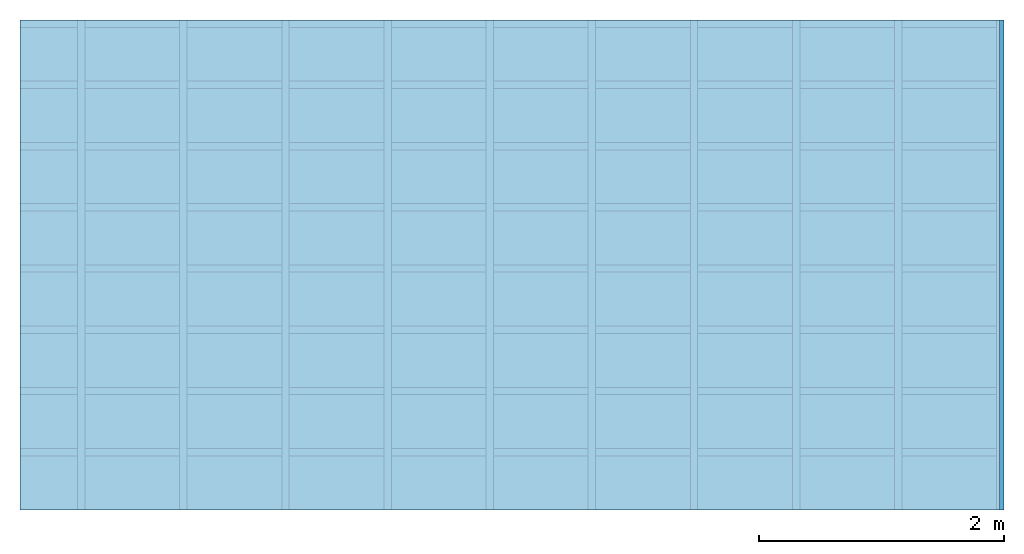
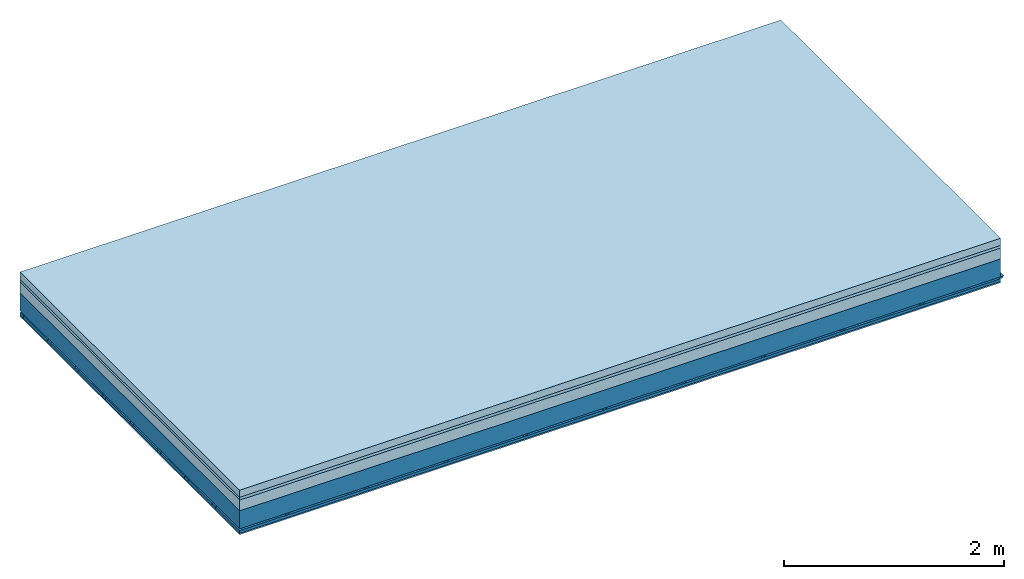
# One storey: 4 members, 4 plates, 1 element without a shape of its own.
"""IFC4 building model written with IfcOpenShell, lengths in metres."""

from ifc_helpers import new_model, si_unit, derived_unit, direction, frame, frame_2d, origin, origin_with_axes, place, context, project, spatial, polyline, rectangle, outline, extrude, material, layer, layer_set, type_object, element, aggregate, save


model = new_model("IFC4")

# Units and contexts
plan_context = context("Plan", 3, precision=1e-05, world=origin(), true_north=direction((0.0, 1.0)))
model_context = context("Model", 3, precision=1e-05, world=origin(), true_north=direction((0.0, 1.0)))
ifc_project = project(units=[si_unit("LENGTHUNIT", "METRE"), derived_unit("SOUNDPRESSUREUNIT", [(si_unit("PRESSUREUNIT", "PASCAL", prefix="MICRO"), 0)]), si_unit("ENERGYUNIT", "JOULE", prefix="MEGA"), si_unit("MASSUNIT", "GRAM", prefix="KILO"), derived_unit("THERMALTRANSMITTANCEUNIT", [(si_unit("POWERUNIT", "WATT"), 1), (si_unit("AREAUNIT", "SQUARE_METRE"), -1), (si_unit("THERMODYNAMICTEMPERATUREUNIT", "KELVIN"), -1)]), derived_unit("AREADENSITYUNIT", [(si_unit("MASSUNIT", "GRAM", prefix="KILO"), 1), (si_unit("AREAUNIT", "SQUARE_METRE"), -1)]), derived_unit("USERDEFINED", [(si_unit("ENERGYUNIT", "JOULE", prefix="MEGA"), 1), (si_unit("AREAUNIT", "SQUARE_METRE"), -1)])], contexts=[plan_context, model_context])

# Site, building, storey
site = spatial("IfcSite", under=ifc_project)
building_placement = place(None, origin())
building = spatial("IfcBuilding", under=site, at=building_placement)
storey_placement = place(building_placement, origin())
storey = spatial("IfcBuildingStorey", under=building, at=storey_placement)

# Slab, members, plates
ifc_material_1 = material(Name="Cement screed", Category="04.006")
ifc_layer_1 = layer(ifc_material_1, 0.08, Name="On-material")
ifc_material_2 = material()
ifc_layer_2 = layer(ifc_material_2, 0.03, Name="Impact sound insulation")
ifc_material_3 = material(Category="03.011")
ifc_layer_3 = layer(ifc_material_3, 0.12, Name="on Supporting structure")
ifc_layer_4 = layer(None, 0.2, Name="Supporting structure")
ifc_material_4 = material(Name="no composite action")
ifc_layer_5 = layer(ifc_material_4, 0.0, Name="Bond")
ifc_layer_6 = layer(None, 0.02, Name="Coupling")
ifc_layer_7 = layer(None, 0.03, Name="Battens / profiles")
ifc_material_5 = material(Category="03.007")
ifc_layer_8 = layer(ifc_material_5, 0.015, Name="Ceiling covering 1st layer")
ifc_material_6 = material(Name="Glued joints")
ifc_layer_9 = layer(ifc_material_6, 0.0, Name="Surface / treatment")
ifc_layer_set = layer_set([ifc_layer_1, ifc_layer_2, ifc_layer_3, ifc_layer_4, ifc_layer_5, ifc_layer_6, ifc_layer_7, ifc_layer_8, ifc_layer_9])
slab_type = type_object("IfcSlabType", Name="A1243", PredefinedType="NOTDEFINED", material=ifc_layer_set)
slab_placement = place(None, frame((0.0, 0.0, 0.0), z_axis=(0.0, 0.0, -1.0), x_axis=(1.0, 0.0, 0.0)))
slab = element("IfcSlab", 1, at=slab_placement, inside=storey, type_object=slab_type, material=ifc_layer_set, Name="Slab #1")
ifc_material_7 = material()
member_1_placement = place(slab_placement, origin())
member_1 = element("IfcMember", 2, at=member_1_placement, material=ifc_material_7, Name="Supporting structure", context=plan_context, shape_type="SweptSolid", body=[
    extrude(rectangle(XDim=1.0, YDim=0.2, at=frame_2d((0.5, 0.1), x_axis=(1.0, 0.0))), frame((0.0, 4.0, 0.23), z_axis=(0.0, -1.0, 0.0), x_axis=(1.0, 0.0, 0.0)), (0.0, 0.0, 1.0), 4.0),
    extrude(rectangle(XDim=1.0, YDim=0.2, at=frame_2d((0.5, 0.1), x_axis=(1.0, 0.0))), frame((1.0, 4.0, 0.23), z_axis=(0.0, -1.0, 0.0), x_axis=(1.0, 0.0, 0.0)), (0.0, 0.0, 1.0), 4.0),
    extrude(rectangle(XDim=1.0, YDim=0.2, at=frame_2d((0.5, 0.1), x_axis=(1.0, 0.0))), frame((2.0, 4.0, 0.23), z_axis=(0.0, -1.0, 0.0), x_axis=(1.0, 0.0, 0.0)), (0.0, 0.0, 1.0), 4.0),
    extrude(rectangle(XDim=1.0, YDim=0.2, at=frame_2d((0.5, 0.1), x_axis=(1.0, 0.0))), frame((3.0, 4.0, 0.23), z_axis=(0.0, -1.0, 0.0), x_axis=(1.0, 0.0, 0.0)), (0.0, 0.0, 1.0), 4.0),
    extrude(rectangle(XDim=1.0, YDim=0.2, at=frame_2d((0.5, 0.1), x_axis=(1.0, 0.0))), frame((4.0, 4.0, 0.23), z_axis=(0.0, -1.0, 0.0), x_axis=(1.0, 0.0, 0.0)), (0.0, 0.0, 1.0), 4.0),
    extrude(rectangle(XDim=1.0, YDim=0.2, at=frame_2d((0.5, 0.1), x_axis=(1.0, 0.0))), frame((5.0, 4.0, 0.23), z_axis=(0.0, -1.0, 0.0), x_axis=(1.0, 0.0, 0.0)), (0.0, 0.0, 1.0), 4.0),
    extrude(rectangle(XDim=1.0, YDim=0.2, at=frame_2d((0.5, 0.1), x_axis=(1.0, 0.0))), frame((6.0, 4.0, 0.23), z_axis=(0.0, -1.0, 0.0), x_axis=(1.0, 0.0, 0.0)), (0.0, 0.0, 1.0), 4.0),
    extrude(rectangle(XDim=1.0, YDim=0.2, at=frame_2d((0.5, 0.1), x_axis=(1.0, 0.0))), frame((7.0, 4.0, 0.23), z_axis=(0.0, -1.0, 0.0), x_axis=(1.0, 0.0, 0.0)), (0.0, 0.0, 1.0), 4.0),
])
ifc_material_8 = material()
member_2_placement = place(slab_placement, origin())
member_2 = element("IfcMember", 3, at=member_2_placement, material=ifc_material_8, Name="Coupling", context=plan_context, shape_type="SweptSolid", body=[
    extrude(outline(polyline([(0.0, 0.0), (0.06, 0.0), (0.04, 0.02), (0.02, 0.02), (0.0, 0.0)])), frame((0.47, 4.0, 0.43), z_axis=(0.0, -1.0, 0.0), x_axis=(1.0, 0.0, 0.0)), (0.0, 0.0, 1.0), 4.0),
    extrude(outline(polyline([(0.0, 0.0), (0.06, 0.0), (0.04, 0.02), (0.02, 0.02), (0.0, 0.0)])), frame((1.304, 4.0, 0.43), z_axis=(0.0, -1.0, 0.0), x_axis=(1.0, 0.0, 0.0)), (0.0, 0.0, 1.0), 4.0),
    extrude(outline(polyline([(0.0, 0.0), (0.06, 0.0), (0.04, 0.02), (0.02, 0.02), (0.0, 0.0)])), frame((2.138, 4.0, 0.43), z_axis=(0.0, -1.0, 0.0), x_axis=(1.0, 0.0, 0.0)), (0.0, 0.0, 1.0), 4.0),
    extrude(outline(polyline([(0.0, 0.0), (0.06, 0.0), (0.04, 0.02), (0.02, 0.02), (0.0, 0.0)])), frame((2.972, 4.0, 0.43), z_axis=(0.0, -1.0, 0.0), x_axis=(1.0, 0.0, 0.0)), (0.0, 0.0, 1.0), 4.0),
    extrude(outline(polyline([(0.0, 0.0), (0.06, 0.0), (0.04, 0.02), (0.02, 0.02), (0.0, 0.0)])), frame((3.806, 4.0, 0.43), z_axis=(0.0, -1.0, 0.0), x_axis=(1.0, 0.0, 0.0)), (0.0, 0.0, 1.0), 4.0),
    extrude(outline(polyline([(0.0, 0.0), (0.06, 0.0), (0.04, 0.02), (0.02, 0.02), (0.0, 0.0)])), frame((4.64, 4.0, 0.43), z_axis=(0.0, -1.0, 0.0), x_axis=(1.0, 0.0, 0.0)), (0.0, 0.0, 1.0), 4.0),
    extrude(outline(polyline([(0.0, 0.0), (0.06, 0.0), (0.04, 0.02), (0.02, 0.02), (0.0, 0.0)])), frame((5.474, 4.0, 0.43), z_axis=(0.0, -1.0, 0.0), x_axis=(1.0, 0.0, 0.0)), (0.0, 0.0, 1.0), 4.0),
    extrude(outline(polyline([(0.0, 0.0), (0.06, 0.0), (0.04, 0.02), (0.02, 0.02), (0.0, 0.0)])), frame((6.308, 4.0, 0.43), z_axis=(0.0, -1.0, 0.0), x_axis=(1.0, 0.0, 0.0)), (0.0, 0.0, 1.0), 4.0),
    extrude(outline(polyline([(0.0, 0.0), (0.06, 0.0), (0.04, 0.02), (0.02, 0.02), (0.0, 0.0)])), frame((7.142, 4.0, 0.43), z_axis=(0.0, -1.0, 0.0), x_axis=(1.0, 0.0, 0.0)), (0.0, 0.0, 1.0), 4.0),
    extrude(outline(polyline([(0.0, 0.0), (0.06, 0.0), (0.04, 0.02), (0.02, 0.02), (0.0, 0.0)])), frame((7.976, 4.0, 0.43), z_axis=(0.0, -1.0, 0.0), x_axis=(1.0, 0.0, 0.0)), (0.0, 0.0, 1.0), 4.0),
])
ifc_material_9 = material()
member_3_placement = place(slab_placement, origin())
member_3 = element("IfcMember", 4, at=member_3_placement, material=ifc_material_9, Name="Battens / profiles", context=plan_context, shape_type="SweptSolid", body=[
    extrude(rectangle(XDim=0.06, YDim=0.03, at=frame_2d((0.03, 0.015), x_axis=(1.0, 0.0))), frame((0.0, 0.0, 0.45), z_axis=(1.0, 0.0, 0.0), x_axis=(0.0, 1.0, 0.0)), (0.0, 0.0, 1.0), 8.0),
    extrude(rectangle(XDim=0.06, YDim=0.03, at=frame_2d((0.03, 0.015), x_axis=(1.0, 0.0))), frame((0.0, 0.5, 0.45), z_axis=(1.0, 0.0, 0.0), x_axis=(0.0, 1.0, 0.0)), (0.0, 0.0, 1.0), 8.0),
    extrude(rectangle(XDim=0.06, YDim=0.03, at=frame_2d((0.03, 0.015), x_axis=(1.0, 0.0))), frame((0.0, 1.0, 0.45), z_axis=(1.0, 0.0, 0.0), x_axis=(0.0, 1.0, 0.0)), (0.0, 0.0, 1.0), 8.0),
    extrude(rectangle(XDim=0.06, YDim=0.03, at=frame_2d((0.03, 0.015), x_axis=(1.0, 0.0))), frame((0.0, 1.5, 0.45), z_axis=(1.0, 0.0, 0.0), x_axis=(0.0, 1.0, 0.0)), (0.0, 0.0, 1.0), 8.0),
    extrude(rectangle(XDim=0.06, YDim=0.03, at=frame_2d((0.03, 0.015), x_axis=(1.0, 0.0))), frame((0.0, 2.0, 0.45), z_axis=(1.0, 0.0, 0.0), x_axis=(0.0, 1.0, 0.0)), (0.0, 0.0, 1.0), 8.0),
    extrude(rectangle(XDim=0.06, YDim=0.03, at=frame_2d((0.03, 0.015), x_axis=(1.0, 0.0))), frame((0.0, 2.5, 0.45), z_axis=(1.0, 0.0, 0.0), x_axis=(0.0, 1.0, 0.0)), (0.0, 0.0, 1.0), 8.0),
    extrude(rectangle(XDim=0.06, YDim=0.03, at=frame_2d((0.03, 0.015), x_axis=(1.0, 0.0))), frame((0.0, 3.0, 0.45), z_axis=(1.0, 0.0, 0.0), x_axis=(0.0, 1.0, 0.0)), (0.0, 0.0, 1.0), 8.0),
    extrude(rectangle(XDim=0.06, YDim=0.03, at=frame_2d((0.03, 0.015), x_axis=(1.0, 0.0))), frame((0.0, 3.5, 0.45), z_axis=(1.0, 0.0, 0.0), x_axis=(0.0, 1.0, 0.0)), (0.0, 0.0, 1.0), 8.0),
])
ifc_material_10 = material()
member_4_placement = place(slab_placement, origin())
member_4 = element("IfcMember", 5, at=member_4_placement, material=ifc_material_10, Name="Cavity", context=plan_context, shape_type="SweptSolid", body=[
    extrude(rectangle(XDim=0.44, YDim=0.03, at=frame_2d((0.22, 0.015), x_axis=(1.0, 0.0))), frame((0.0, 0.06, 0.45), z_axis=(1.0, 0.0, 0.0), x_axis=(0.0, 1.0, 0.0)), (0.0, 0.0, 1.0), 8.0),
    extrude(rectangle(XDim=0.44, YDim=0.03, at=frame_2d((0.22, 0.015), x_axis=(1.0, 0.0))), frame((0.0, 0.56, 0.45), z_axis=(1.0, 0.0, 0.0), x_axis=(0.0, 1.0, 0.0)), (0.0, 0.0, 1.0), 8.0),
    extrude(rectangle(XDim=0.44, YDim=0.03, at=frame_2d((0.22, 0.015), x_axis=(1.0, 0.0))), frame((0.0, 1.06, 0.45), z_axis=(1.0, 0.0, 0.0), x_axis=(0.0, 1.0, 0.0)), (0.0, 0.0, 1.0), 8.0),
    extrude(rectangle(XDim=0.44, YDim=0.03, at=frame_2d((0.22, 0.015), x_axis=(1.0, 0.0))), frame((0.0, 1.56, 0.45), z_axis=(1.0, 0.0, 0.0), x_axis=(0.0, 1.0, 0.0)), (0.0, 0.0, 1.0), 8.0),
    extrude(rectangle(XDim=0.44, YDim=0.03, at=frame_2d((0.22, 0.015), x_axis=(1.0, 0.0))), frame((0.0, 2.06, 0.45), z_axis=(1.0, 0.0, 0.0), x_axis=(0.0, 1.0, 0.0)), (0.0, 0.0, 1.0), 8.0),
    extrude(rectangle(XDim=0.44, YDim=0.03, at=frame_2d((0.22, 0.015), x_axis=(1.0, 0.0))), frame((0.0, 2.56, 0.45), z_axis=(1.0, 0.0, 0.0), x_axis=(0.0, 1.0, 0.0)), (0.0, 0.0, 1.0), 8.0),
    extrude(rectangle(XDim=0.44, YDim=0.03, at=frame_2d((0.22, 0.015), x_axis=(1.0, 0.0))), frame((0.0, 3.06, 0.45), z_axis=(1.0, 0.0, 0.0), x_axis=(0.0, 1.0, 0.0)), (0.0, 0.0, 1.0), 8.0),
    extrude(rectangle(XDim=0.44, YDim=0.03, at=frame_2d((0.22, 0.015), x_axis=(1.0, 0.0))), frame((0.0, 3.56, 0.45), z_axis=(1.0, 0.0, 0.0), x_axis=(0.0, 1.0, 0.0)), (0.0, 0.0, 1.0), 8.0),
])
plate_1_placement = place(slab_placement, origin())
plate_1 = element("IfcPlate", 6, at=plate_1_placement, material=ifc_material_1, Name="On-material", context=plan_context, shape_type="SweptSolid", body=[
    extrude(rectangle(XDim=8.0, YDim=4.0, at=frame_2d((4.0, 2.0), x_axis=(1.0, 0.0))), origin_with_axes(), (0.0, 0.0, 1.0), 0.08),
])
plate_2_placement = place(slab_placement, origin())
plate_2 = element("IfcPlate", 7, at=plate_2_placement, material=ifc_material_2, Name="Impact sound insulation", context=plan_context, shape_type="SweptSolid", body=[
    extrude(rectangle(XDim=8.0, YDim=4.0, at=frame_2d((4.0, 2.0), x_axis=(1.0, 0.0))), frame((0.0, 0.0, 0.08), z_axis=(0.0, 0.0, 1.0), x_axis=(1.0, 0.0, 0.0)), (0.0, 0.0, 1.0), 0.03),
])
plate_3_placement = place(slab_placement, origin())
plate_3 = element("IfcPlate", 8, at=plate_3_placement, material=ifc_material_3, Name="on Supporting structure", context=plan_context, shape_type="SweptSolid", body=[
    extrude(rectangle(XDim=8.0, YDim=4.0, at=frame_2d((4.0, 2.0), x_axis=(1.0, 0.0))), frame((0.0, 0.0, 0.11), z_axis=(0.0, 0.0, 1.0), x_axis=(1.0, 0.0, 0.0)), (0.0, 0.0, 1.0), 0.12),
])
plate_4_placement = place(slab_placement, origin())
plate_4 = element("IfcPlate", 9, at=plate_4_placement, material=ifc_material_5, Name="Ceiling covering 1st layer", context=plan_context, shape_type="SweptSolid", body=[
    extrude(rectangle(XDim=8.0, YDim=4.0, at=frame_2d((4.0, 2.0), x_axis=(1.0, 0.0))), frame((0.0, 0.0, 0.48), z_axis=(0.0, 0.0, 1.0), x_axis=(1.0, 0.0, 0.0)), (0.0, 0.0, 1.0), 0.015),
])
aggregate(slab, [plate_1, plate_2, plate_3, member_1, member_2, member_3, member_4, plate_4])

save(model, "model.ifc")
